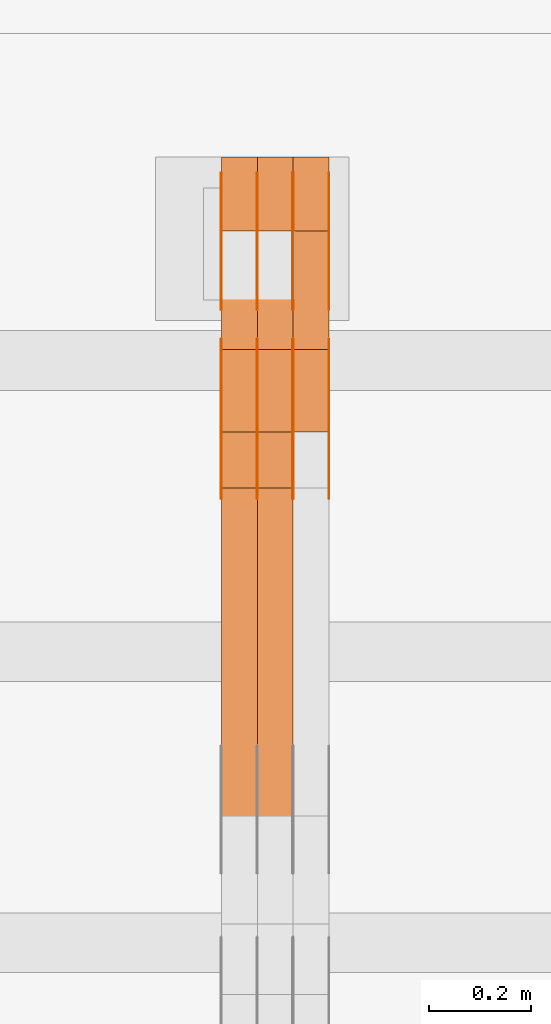
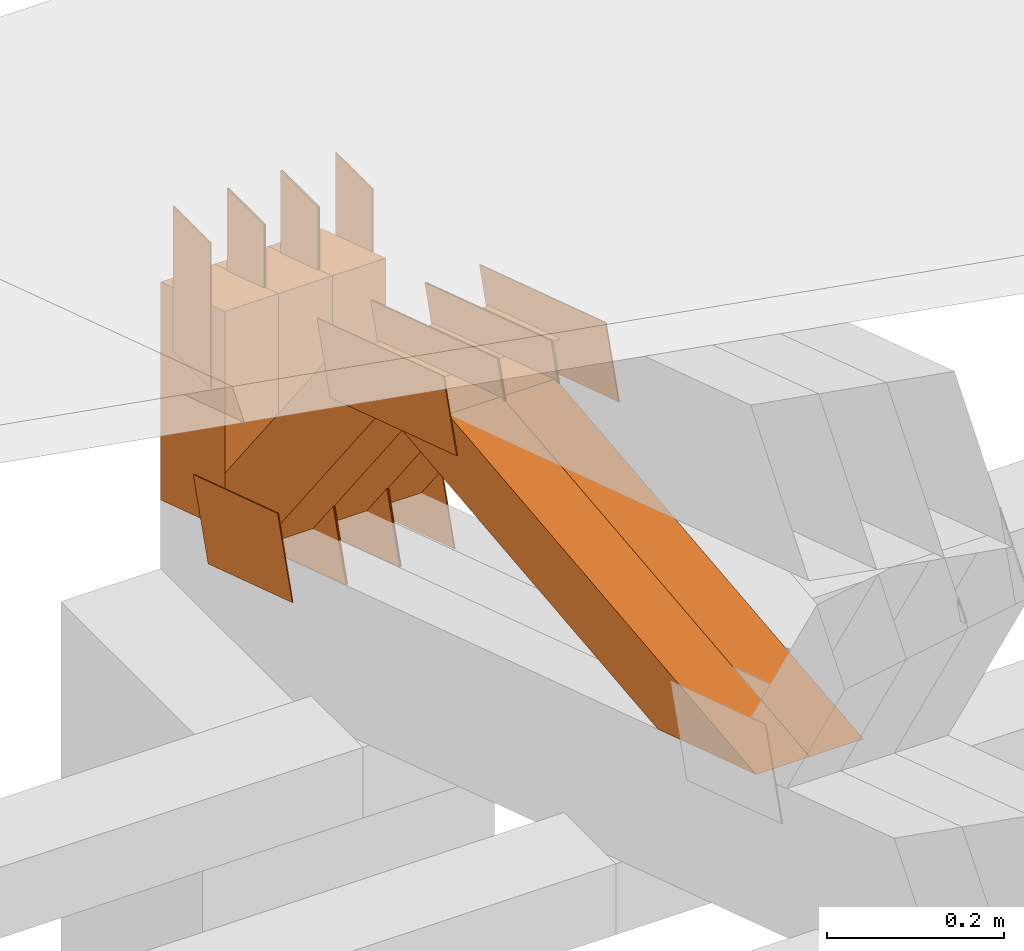
# One storey, part 242 of 385: 26 proxies.
"""IFC2X3 building model written with IfcOpenShell, lengths in millimetres."""

from ifc_helpers import new_model, entity, si_unit, converted_unit, derived_unit, direction, frame, frame_2d, origin, place, context, subcontext, project, spatial, polyline, rectangle, outline, extrude, source, transform, mapped, material, type_object, type_shapes, element, save


model = new_model("IFC2X3")

# Units and contexts
model_context = context("Model", 3, precision=0.01, world=origin(), true_north=direction((6.12303176911189e-17, 1.0)))
body_context = subcontext(model_context, "Body", "Model", "MODEL_VIEW")
ifc_project = project(units=[si_unit("LENGTHUNIT", "METRE", prefix="MILLI"), si_unit("AREAUNIT", "SQUARE_METRE"), si_unit("VOLUMEUNIT", "CUBIC_METRE"), converted_unit("PLANEANGLEUNIT", "DEGREE", entity("IfcRatioMeasure", 0.0174532925199433), si_unit("PLANEANGLEUNIT", "RADIAN"), dimensions=[0, 0, 0, 0, 0, 0, 0]), si_unit("MASSUNIT", "GRAM", prefix="KILO"), derived_unit("MASSDENSITYUNIT", [(si_unit("MASSUNIT", "GRAM", prefix="KILO"), 1), (si_unit("LENGTHUNIT", "METRE"), -3)]), si_unit("TIMEUNIT", "SECOND"), si_unit("FREQUENCYUNIT", "HERTZ"), si_unit("THERMODYNAMICTEMPERATUREUNIT", "DEGREE_CELSIUS"), derived_unit("THERMALTRANSMITTANCEUNIT", [(si_unit("MASSUNIT", "GRAM", prefix="KILO"), 1), (si_unit("THERMODYNAMICTEMPERATUREUNIT", "KELVIN"), -1), (si_unit("TIMEUNIT", "SECOND"), -3)]), derived_unit("VOLUMETRICFLOWRATEUNIT", [(si_unit("LENGTHUNIT", "METRE"), 3), (si_unit("TIMEUNIT", "SECOND"), -1)]), si_unit("ELECTRICCURRENTUNIT", "AMPERE"), si_unit("ELECTRICVOLTAGEUNIT", "VOLT"), si_unit("POWERUNIT", "WATT"), si_unit("FORCEUNIT", "NEWTON", prefix="KILO"), si_unit("ILLUMINANCEUNIT", "LUX"), si_unit("LUMINOUSFLUXUNIT", "LUMEN"), si_unit("LUMINOUSINTENSITYUNIT", "CANDELA"), derived_unit("USERDEFINED", [(si_unit("MASSUNIT", "GRAM", prefix="KILO"), -1), (si_unit("LENGTHUNIT", "METRE"), -2), (si_unit("TIMEUNIT", "SECOND"), 3), (si_unit("LUMINOUSFLUXUNIT", "LUMEN"), 1)]), derived_unit("LINEARVELOCITYUNIT", [(si_unit("LENGTHUNIT", "METRE"), 1), (si_unit("TIMEUNIT", "SECOND"), -1)]), si_unit("PRESSUREUNIT", "PASCAL"), derived_unit("USERDEFINED", [(si_unit("LENGTHUNIT", "METRE"), -2), (si_unit("MASSUNIT", "GRAM", prefix="KILO"), 1), (si_unit("TIMEUNIT", "SECOND"), -2)])], contexts=[model_context])

# Site, building, storey
site_placement = place(None, origin())
site = spatial("IfcSite", under=ifc_project, at=site_placement, CompositionType="ELEMENT")
building_placement = place(site_placement, origin())
building = spatial("IfcBuilding", under=site, at=building_placement, CompositionType="ELEMENT")
storey_placement = place(building_placement, origin())
storey = spatial("IfcBuildingStorey", under=building, at=storey_placement, Name="Default", CompositionType="ELEMENT", Elevation=0.0)

# Proxies
ifc_material_1 = material(Name="IfcSurfaceStyle #378222")
building_element_proxy_type_1 = type_object("IfcBuildingElementProxyType", PredefinedType="NOTDEFINED", material=ifc_material_1)
shared_shape_1 = source(origin(), body_context, "Body", "SweptSolid", [
    extrude(outline(polyline([(-100.000024997547, -54.0000105875654), (100.000088940899, -54.0000105875654), (99.9999100805868, 54.0000105875654), (-99.9999740239394, 54.0000105875654), (-100.000024997547, -54.0000105875654)])), frame((100.000088940899, 54.0000474633838, 0.0), z_axis=(0.0, 0.0, 1.0), x_axis=(-1.0, 0.0, 0.0)), (0.0, 0.0, 1.0), 1.3),
])
type_shapes(building_element_proxy_type_1, [shared_shape_1])
proxy_1_placement = place(building_placement, frame((30386.3, 26390.6212638563, 73.3227520411355), z_axis=(-1.0, 0.0, 0.0), x_axis=(0.0, -0.951056516295124, 0.309016994375039)))
element("IfcBuildingElementProxy", 1, at=proxy_1_placement, inside=storey, type_object=building_element_proxy_type_1, material=ifc_material_1, context=body_context, shape_type="MappedRepresentation", body=[
    mapped(shared_shape_1, transform((0.0, 0.0, 0.0), scale=1.0)),
])
ifc_material_2 = material(Name="IfcSurfaceStyle #378165")
building_element_proxy_type_2 = type_object("IfcBuildingElementProxyType", PredefinedType="NOTDEFINED", material=ifc_material_2)
shared_shape_2 = source(origin(), body_context, "Body", "SweptSolid", [
    extrude(outline(polyline([(-100.000024997547, -54.0000105875654), (100.000088940899, -54.0000105875654), (99.9999100805868, 54.0000105875654), (-99.9999740239394, 54.0000105875654), (-100.000024997547, -54.0000105875654)])), frame((100.000088940899, 54.0000474633838, 0.0), z_axis=(0.0, 0.0, 1.0), x_axis=(-1.0, 0.0, 0.0)), (0.0, 0.0, 1.0), 1.3),
])
type_shapes(building_element_proxy_type_2, [shared_shape_2])
proxy_2_placement = place(building_placement, frame((30315.0, 26390.6212638563, 73.3227520411355), z_axis=(-1.0, 0.0, 0.0), x_axis=(0.0, -0.951056516295124, 0.309016994375039)))
element("IfcBuildingElementProxy", 2, at=proxy_2_placement, inside=storey, type_object=building_element_proxy_type_2, material=ifc_material_2, context=body_context, shape_type="MappedRepresentation", body=[
    mapped(shared_shape_2, transform((0.0, 0.0, 0.0), scale=1.0)),
])
ifc_material_3 = material(Name="IfcSurfaceStyle #378108")
building_element_proxy_type_3 = type_object("IfcBuildingElementProxyType", PredefinedType="NOTDEFINED", material=ifc_material_3)
shared_shape_3 = source(origin(), body_context, "Body", "SweptSolid", [
    extrude(outline(polyline([(-100.000024997547, -54.0000105875654), (100.000088940899, -54.0000105875654), (99.9999100805868, 54.0000105875654), (-99.9999740239394, 54.0000105875654), (-100.000024997547, -54.0000105875654)])), frame((100.000088940899, 54.0000474633838, 0.0), z_axis=(0.0, 0.0, 1.0), x_axis=(-1.0, 0.0, 0.0)), (0.0, 0.0, 1.0), 1.3),
])
type_shapes(building_element_proxy_type_3, [shared_shape_3])
proxy_3_placement = place(building_placement, frame((30316.3, 26390.6212638563, 73.3227520411355), z_axis=(-1.0, 0.0, 0.0), x_axis=(0.0, -0.951056516295124, 0.309016994375039)))
element("IfcBuildingElementProxy", 3, at=proxy_3_placement, inside=storey, type_object=building_element_proxy_type_3, material=ifc_material_3, context=body_context, shape_type="MappedRepresentation", body=[
    mapped(shared_shape_3, transform((0.0, 0.0, 0.0), scale=1.0)),
])
ifc_material_4 = material(Name="IfcSurfaceStyle #378051")
building_element_proxy_type_4 = type_object("IfcBuildingElementProxyType", PredefinedType="NOTDEFINED", material=ifc_material_4)
shared_shape_4 = source(origin(), body_context, "Body", "SweptSolid", [
    extrude(outline(polyline([(-100.000024997547, -54.0000105875654), (100.000088940899, -54.0000105875654), (99.9999100805868, 54.0000105875654), (-99.9999740239394, 54.0000105875654), (-100.000024997547, -54.0000105875654)])), frame((100.000088940899, 54.0000474633838, 0.0), z_axis=(0.0, 0.0, 1.0), x_axis=(-1.0, 0.0, 0.0)), (0.0, 0.0, 1.0), 1.29999999999998),
])
type_shapes(building_element_proxy_type_4, [shared_shape_4])
proxy_4_placement = place(building_placement, frame((30245.0, 26390.6212638563, 73.3227520411355), z_axis=(-1.0, 0.0, 0.0), x_axis=(0.0, -0.951056516295124, 0.309016994375039)))
element("IfcBuildingElementProxy", 4, at=proxy_4_placement, inside=storey, type_object=building_element_proxy_type_4, material=ifc_material_4, context=body_context, shape_type="MappedRepresentation", body=[
    mapped(shared_shape_4, transform((0.0, 0.0, 0.0), scale=1.0)),
])
ifc_material_5 = material(Name="IfcSurfaceStyle #377994")
building_element_proxy_type_5 = type_object("IfcBuildingElementProxyType", PredefinedType="NOTDEFINED", material=ifc_material_5)
shared_shape_5 = source(origin(), body_context, "Body", "SweptSolid", [
    extrude(outline(polyline([(-100.000024997547, -54.0000105875654), (100.000088940899, -54.0000105875654), (99.9999100805868, 54.0000105875654), (-99.9999740239394, 54.0000105875654), (-100.000024997547, -54.0000105875654)])), frame((100.000088940899, 54.0000474633838, 0.0), z_axis=(0.0, 0.0, 1.0), x_axis=(-1.0, 0.0, 0.0)), (0.0, 0.0, 1.0), 1.29999999999998),
])
type_shapes(building_element_proxy_type_5, [shared_shape_5])
proxy_5_placement = place(building_placement, frame((30246.3, 26390.6212638563, 73.3227520411355), z_axis=(-1.0, 0.0, 0.0), x_axis=(0.0, -0.951056516295124, 0.309016994375039)))
element("IfcBuildingElementProxy", 5, at=proxy_5_placement, inside=storey, type_object=building_element_proxy_type_5, material=ifc_material_5, context=body_context, shape_type="MappedRepresentation", body=[
    mapped(shared_shape_5, transform((0.0, 0.0, 0.0), scale=1.0)),
])
ifc_material_6 = material(Name="IfcSurfaceStyle #377937")
building_element_proxy_type_6 = type_object("IfcBuildingElementProxyType", PredefinedType="NOTDEFINED", material=ifc_material_6)
shared_shape_6 = source(origin(), body_context, "Body", "SweptSolid", [
    extrude(outline(polyline([(-100.000024997547, -54.0000105875654), (100.000088940899, -54.0000105875654), (99.9999100805868, 54.0000105875654), (-99.9999740239394, 54.0000105875654), (-100.000024997547, -54.0000105875654)])), frame((100.000088940899, 54.0000474633838, 0.0), z_axis=(0.0, 0.0, 1.0), x_axis=(-1.0, 0.0, 0.0)), (0.0, 0.0, 1.0), 1.29999999999999),
])
type_shapes(building_element_proxy_type_6, [shared_shape_6])
proxy_6_placement = place(building_placement, frame((30175.0, 26390.6212638563, 73.3227520411355), z_axis=(-1.0, 0.0, 0.0), x_axis=(0.0, -0.951056516295124, 0.309016994375039)))
element("IfcBuildingElementProxy", 6, at=proxy_6_placement, inside=storey, type_object=building_element_proxy_type_6, material=ifc_material_6, context=body_context, shape_type="MappedRepresentation", body=[
    mapped(shared_shape_6, transform((0.0, 0.0, 0.0), scale=1.0)),
])
ifc_material_7 = material(Name="IfcSurfaceStyle #365568")
building_element_proxy_type_7 = type_object("IfcBuildingElementProxyType", PredefinedType="NOTDEFINED", material=ifc_material_7)
shared_shape_7 = source(origin(), body_context, "Body", "SweptSolid", [
    extrude(outline(polyline([(-149.999901061401, -48.0000057587028), (150.000035297123, -48.0000057587028), (149.999910491851, 48.0000057587028), (-150.000044727574, 48.0000057587028), (-149.999901061401, -48.0000057587028)])), frame((150.000035297123, 48.0000632585775, 0.0), z_axis=(0.0, 0.0, 1.0), x_axis=(-1.0, 0.0, 0.0)), (0.0, 0.0, 1.0), 1.29999999999999),
])
type_shapes(building_element_proxy_type_7, [shared_shape_7])
proxy_7_placement = place(building_placement, frame((30386.3, 26115.0176968219, 469.58296924555), z_axis=(-1.0, 0.0, 0.0), x_axis=(0.0, -0.951056516295154, 0.309016994374948)))
element("IfcBuildingElementProxy", 7, at=proxy_7_placement, inside=storey, type_object=building_element_proxy_type_7, material=ifc_material_7, context=body_context, shape_type="MappedRepresentation", body=[
    mapped(shared_shape_7, transform((0.0, 0.0, 0.0), scale=1.0)),
])
ifc_material_8 = material(Name="IfcSurfaceStyle #365511")
building_element_proxy_type_8 = type_object("IfcBuildingElementProxyType", PredefinedType="NOTDEFINED", material=ifc_material_8)
shared_shape_8 = source(origin(), body_context, "Body", "SweptSolid", [
    extrude(outline(polyline([(-149.999901061401, -48.0000057587028), (150.000035297123, -48.0000057587028), (149.999910491851, 48.0000057587028), (-150.000044727574, 48.0000057587028), (-149.999901061401, -48.0000057587028)])), frame((150.000035297123, 48.0000632585775, 0.0), z_axis=(0.0, 0.0, 1.0), x_axis=(-1.0, 0.0, 0.0)), (0.0, 0.0, 1.0), 1.29999999999999),
])
type_shapes(building_element_proxy_type_8, [shared_shape_8])
proxy_8_placement = place(building_placement, frame((30315.0, 26115.0176968219, 469.58296924555), z_axis=(-1.0, 0.0, 0.0), x_axis=(0.0, -0.951056516295154, 0.309016994374948)))
element("IfcBuildingElementProxy", 8, at=proxy_8_placement, inside=storey, type_object=building_element_proxy_type_8, material=ifc_material_8, context=body_context, shape_type="MappedRepresentation", body=[
    mapped(shared_shape_8, transform((0.0, 0.0, 0.0), scale=1.0)),
])
ifc_material_9 = material(Name="IfcSurfaceStyle #365454")
building_element_proxy_type_9 = type_object("IfcBuildingElementProxyType", PredefinedType="NOTDEFINED", material=ifc_material_9)
shared_shape_9 = source(origin(), body_context, "Body", "SweptSolid", [
    extrude(outline(polyline([(-149.999901061401, -48.0000057587028), (150.000035297123, -48.0000057587028), (149.999910491851, 48.0000057587028), (-150.000044727574, 48.0000057587028), (-149.999901061401, -48.0000057587028)])), frame((150.000035297123, 48.0000632585775, 0.0), z_axis=(0.0, 0.0, 1.0), x_axis=(-1.0, 0.0, 0.0)), (0.0, 0.0, 1.0), 1.29999999999999),
])
type_shapes(building_element_proxy_type_9, [shared_shape_9])
proxy_9_placement = place(building_placement, frame((30316.3, 26115.0176968219, 469.58296924555), z_axis=(-1.0, 0.0, 0.0), x_axis=(0.0, -0.951056516295154, 0.309016994374948)))
element("IfcBuildingElementProxy", 9, at=proxy_9_placement, inside=storey, type_object=building_element_proxy_type_9, material=ifc_material_9, context=body_context, shape_type="MappedRepresentation", body=[
    mapped(shared_shape_9, transform((0.0, 0.0, 0.0), scale=1.0)),
])
ifc_material_10 = material(Name="IfcSurfaceStyle #365397")
building_element_proxy_type_10 = type_object("IfcBuildingElementProxyType", PredefinedType="NOTDEFINED", material=ifc_material_10)
shared_shape_10 = source(origin(), body_context, "Body", "SweptSolid", [
    extrude(outline(polyline([(-149.999901061401, -48.0000057587028), (150.000035297123, -48.0000057587028), (149.999910491851, 48.0000057587028), (-150.000044727574, 48.0000057587028), (-149.999901061401, -48.0000057587028)])), frame((150.000035297123, 48.0000632585775, 0.0), z_axis=(0.0, 0.0, 1.0), x_axis=(-1.0, 0.0, 0.0)), (0.0, 0.0, 1.0), 1.29999999999998),
])
type_shapes(building_element_proxy_type_10, [shared_shape_10])
proxy_10_placement = place(building_placement, frame((30245.0, 26115.0176968219, 469.58296924555), z_axis=(-1.0, 0.0, 0.0), x_axis=(0.0, -0.951056516295154, 0.309016994374948)))
element("IfcBuildingElementProxy", 10, at=proxy_10_placement, inside=storey, type_object=building_element_proxy_type_10, material=ifc_material_10, context=body_context, shape_type="MappedRepresentation", body=[
    mapped(shared_shape_10, transform((0.0, 0.0, 0.0), scale=1.0)),
])
ifc_material_11 = material(Name="IfcSurfaceStyle #365340")
building_element_proxy_type_11 = type_object("IfcBuildingElementProxyType", PredefinedType="NOTDEFINED", material=ifc_material_11)
shared_shape_11 = source(origin(), body_context, "Body", "SweptSolid", [
    extrude(outline(polyline([(-149.999901061401, -48.0000057587028), (150.000035297123, -48.0000057587028), (149.999910491851, 48.0000057587028), (-150.000044727574, 48.0000057587028), (-149.999901061401, -48.0000057587028)])), frame((150.000035297123, 48.0000632585775, 0.0), z_axis=(0.0, 0.0, 1.0), x_axis=(-1.0, 0.0, 0.0)), (0.0, 0.0, 1.0), 1.29999999999998),
])
type_shapes(building_element_proxy_type_11, [shared_shape_11])
proxy_11_placement = place(building_placement, frame((30246.3, 26115.0176968219, 469.58296924555), z_axis=(-1.0, 0.0, 0.0), x_axis=(0.0, -0.951056516295154, 0.309016994374948)))
element("IfcBuildingElementProxy", 11, at=proxy_11_placement, inside=storey, type_object=building_element_proxy_type_11, material=ifc_material_11, context=body_context, shape_type="MappedRepresentation", body=[
    mapped(shared_shape_11, transform((0.0, 0.0, 0.0), scale=1.0)),
])
ifc_material_12 = material(Name="IfcSurfaceStyle #365283")
building_element_proxy_type_12 = type_object("IfcBuildingElementProxyType", PredefinedType="NOTDEFINED", material=ifc_material_12)
shared_shape_12 = source(origin(), body_context, "Body", "SweptSolid", [
    extrude(outline(polyline([(-149.999901061401, -48.0000057587028), (150.000035297123, -48.0000057587028), (149.999910491851, 48.0000057587028), (-150.000044727574, 48.0000057587028), (-149.999901061401, -48.0000057587028)])), frame((150.000035297123, 48.0000632585775, 0.0), z_axis=(0.0, 0.0, 1.0), x_axis=(-1.0, 0.0, 0.0)), (0.0, 0.0, 1.0), 1.29999999999998),
])
type_shapes(building_element_proxy_type_12, [shared_shape_12])
proxy_12_placement = place(building_placement, frame((30175.0, 26115.0176968219, 469.58296924555), z_axis=(-1.0, 0.0, 0.0), x_axis=(0.0, -0.951056516295154, 0.309016994374948)))
element("IfcBuildingElementProxy", 12, at=proxy_12_placement, inside=storey, type_object=building_element_proxy_type_12, material=ifc_material_12, context=body_context, shape_type="MappedRepresentation", body=[
    mapped(shared_shape_12, transform((0.0, 0.0, 0.0), scale=1.0)),
])
ifc_material_13 = material(Name="IfcSurfaceStyle #365226")
building_element_proxy_type_13 = type_object("IfcBuildingElementProxyType", PredefinedType="NOTDEFINED", material=ifc_material_13)
shared_shape_13 = source(origin(), body_context, "Body", "SweptSolid", [
    extrude(rectangle(XDim=200.0, YDim=84.0000000000005, at=frame_2d((-2.1316282072803e-14, 1.06581410364015e-14), x_axis=(1.0, 0.0))), frame((100.0, 42.0, 0.0), z_axis=(0.0, 0.0, 1.0), x_axis=(-1.0, 0.0, 0.0)), (0.0, 0.0, 1.0), 1.3),
])
type_shapes(building_element_proxy_type_13, [shared_shape_13])
proxy_13_placement = place(building_placement, frame((30386.3, 26469.5000000002, 518.521545410156), z_axis=(-1.0, 0.0, 0.0), x_axis=(0.0, 0.0, -1.0)))
element("IfcBuildingElementProxy", 13, at=proxy_13_placement, inside=storey, type_object=building_element_proxy_type_13, material=ifc_material_13, context=body_context, shape_type="MappedRepresentation", body=[
    mapped(shared_shape_13, transform((0.0, 0.0, 0.0), scale=1.0)),
])
ifc_material_14 = material(Name="IfcSurfaceStyle #365169")
building_element_proxy_type_14 = type_object("IfcBuildingElementProxyType", PredefinedType="NOTDEFINED", material=ifc_material_14)
shared_shape_14 = source(origin(), body_context, "Body", "SweptSolid", [
    extrude(rectangle(XDim=200.0, YDim=84.0000000000005, at=frame_2d((-2.1316282072803e-14, 1.06581410364015e-14), x_axis=(1.0, 0.0))), frame((100.0, 42.0, 0.0), z_axis=(0.0, 0.0, 1.0), x_axis=(-1.0, 0.0, 0.0)), (0.0, 0.0, 1.0), 1.3),
])
type_shapes(building_element_proxy_type_14, [shared_shape_14])
proxy_14_placement = place(building_placement, frame((30315.0, 26469.5000000002, 518.521545410156), z_axis=(-1.0, 0.0, 0.0), x_axis=(0.0, 0.0, -1.0)))
element("IfcBuildingElementProxy", 14, at=proxy_14_placement, inside=storey, type_object=building_element_proxy_type_14, material=ifc_material_14, context=body_context, shape_type="MappedRepresentation", body=[
    mapped(shared_shape_14, transform((0.0, 0.0, 0.0), scale=1.0)),
])
ifc_material_15 = material(Name="IfcSurfaceStyle #365112")
building_element_proxy_type_15 = type_object("IfcBuildingElementProxyType", PredefinedType="NOTDEFINED", material=ifc_material_15)
shared_shape_15 = source(origin(), body_context, "Body", "SweptSolid", [
    extrude(rectangle(XDim=200.0, YDim=84.0000000000005, at=frame_2d((-2.1316282072803e-14, 1.06581410364015e-14), x_axis=(1.0, 0.0))), frame((100.0, 42.0, 0.0), z_axis=(0.0, 0.0, 1.0), x_axis=(-1.0, 0.0, 0.0)), (0.0, 0.0, 1.0), 1.3),
])
type_shapes(building_element_proxy_type_15, [shared_shape_15])
proxy_15_placement = place(building_placement, frame((30316.3, 26469.5000000002, 518.521545410156), z_axis=(-1.0, 0.0, 0.0), x_axis=(0.0, 0.0, -1.0)))
element("IfcBuildingElementProxy", 15, at=proxy_15_placement, inside=storey, type_object=building_element_proxy_type_15, material=ifc_material_15, context=body_context, shape_type="MappedRepresentation", body=[
    mapped(shared_shape_15, transform((0.0, 0.0, 0.0), scale=1.0)),
])
ifc_material_16 = material(Name="IfcSurfaceStyle #365055")
building_element_proxy_type_16 = type_object("IfcBuildingElementProxyType", PredefinedType="NOTDEFINED", material=ifc_material_16)
shared_shape_16 = source(origin(), body_context, "Body", "SweptSolid", [
    extrude(rectangle(XDim=200.0, YDim=84.0000000000005, at=frame_2d((-2.1316282072803e-14, 1.06581410364015e-14), x_axis=(1.0, 0.0))), frame((100.0, 42.0, 0.0), z_axis=(0.0, 0.0, 1.0), x_axis=(-1.0, 0.0, 0.0)), (0.0, 0.0, 1.0), 1.29999999999998),
])
type_shapes(building_element_proxy_type_16, [shared_shape_16])
proxy_16_placement = place(building_placement, frame((30245.0, 26469.5000000002, 518.521545410156), z_axis=(-1.0, 0.0, 0.0), x_axis=(0.0, 0.0, -1.0)))
element("IfcBuildingElementProxy", 16, at=proxy_16_placement, inside=storey, type_object=building_element_proxy_type_16, material=ifc_material_16, context=body_context, shape_type="MappedRepresentation", body=[
    mapped(shared_shape_16, transform((0.0, 0.0, 0.0), scale=1.0)),
])
ifc_material_17 = material(Name="IfcSurfaceStyle #364998")
building_element_proxy_type_17 = type_object("IfcBuildingElementProxyType", PredefinedType="NOTDEFINED", material=ifc_material_17)
shared_shape_17 = source(origin(), body_context, "Body", "SweptSolid", [
    extrude(rectangle(XDim=200.0, YDim=84.0000000000005, at=frame_2d((-2.1316282072803e-14, 1.06581410364015e-14), x_axis=(1.0, 0.0))), frame((100.0, 42.0, 0.0), z_axis=(0.0, 0.0, 1.0), x_axis=(-1.0, 0.0, 0.0)), (0.0, 0.0, 1.0), 1.29999999999998),
])
type_shapes(building_element_proxy_type_17, [shared_shape_17])
proxy_17_placement = place(building_placement, frame((30246.3, 26469.5000000002, 518.521545410156), z_axis=(-1.0, 0.0, 0.0), x_axis=(0.0, 0.0, -1.0)))
element("IfcBuildingElementProxy", 17, at=proxy_17_placement, inside=storey, type_object=building_element_proxy_type_17, material=ifc_material_17, context=body_context, shape_type="MappedRepresentation", body=[
    mapped(shared_shape_17, transform((0.0, 0.0, 0.0), scale=1.0)),
])
ifc_material_18 = material(Name="IfcSurfaceStyle #364941")
building_element_proxy_type_18 = type_object("IfcBuildingElementProxyType", PredefinedType="NOTDEFINED", material=ifc_material_18)
shared_shape_18 = source(origin(), body_context, "Body", "SweptSolid", [
    extrude(rectangle(XDim=200.0, YDim=84.0000000000005, at=frame_2d((-2.1316282072803e-14, 1.06581410364015e-14), x_axis=(1.0, 0.0))), frame((100.0, 42.0, 0.0), z_axis=(0.0, 0.0, 1.0), x_axis=(-1.0, 0.0, 0.0)), (0.0, 0.0, 1.0), 1.29999999999999),
])
type_shapes(building_element_proxy_type_18, [shared_shape_18])
proxy_18_placement = place(building_placement, frame((30175.0, 26469.5000000002, 518.521545410156), z_axis=(-1.0, 0.0, 0.0), x_axis=(0.0, 0.0, -1.0)))
element("IfcBuildingElementProxy", 18, at=proxy_18_placement, inside=storey, type_object=building_element_proxy_type_18, material=ifc_material_18, context=body_context, shape_type="MappedRepresentation", body=[
    mapped(shared_shape_18, transform((0.0, 0.0, 0.0), scale=1.0)),
])
ifc_material_19 = material(Name="IfcSurfaceStyle #353748")
building_element_proxy_type_19 = type_object("IfcBuildingElementProxyType", Name="T1-W4 353746", PredefinedType="NOTDEFINED", material=ifc_material_19)
shared_shape_19 = source(origin(), body_context, "Body", "SweptSolid", [
    extrude(outline(polyline([(-510.077325435179, -47.4999981284922), (188.854793418912, -47.4999981284922), (294.906688207675, 1.67015383116809e-05), (324.289382923648, 47.499989777723), (-297.973539115057, 47.4999897777231), (-510.077325435179, -47.4999981284922)])), frame((324.289382923648, 47.5000278316275, 0.0), z_axis=(0.0, 0.0, 1.0), x_axis=(-1.0, 0.0, 0.0)), (0.0, 0.0, 1.0), 70.0),
])
type_shapes(building_element_proxy_type_19, [shared_shape_19])
proxy_19_placement = place(building_placement, frame((30315.0, 25996.2241251556, 525.69905884318), z_axis=(-1.0, 0.0, 0.0), x_axis=(0.0, -0.994287125203057, -0.106738524701444)))
element("IfcBuildingElementProxy", 19, at=proxy_19_placement, inside=storey, type_object=building_element_proxy_type_19, material=ifc_material_19, Name="T1-W4", context=body_context, shape_type="MappedRepresentation", body=[
    mapped(shared_shape_19, transform((0.0, 0.0, 0.0), scale=1.0)),
])
ifc_material_20 = material(Name="IfcSurfaceStyle #353682")
building_element_proxy_type_20 = type_object("IfcBuildingElementProxyType", Name="T1-W4 353680", PredefinedType="NOTDEFINED", material=ifc_material_20)
shared_shape_20 = source(origin(), body_context, "Body", "SweptSolid", [
    extrude(outline(polyline([(-510.077325435179, -47.4999981284922), (188.854793418912, -47.4999981284922), (294.906688207675, 1.67015383116809e-05), (324.289382923648, 47.499989777723), (-297.973539115057, 47.4999897777231), (-510.077325435179, -47.4999981284922)])), frame((324.289382923648, 47.5000278316275, 0.0), z_axis=(0.0, 0.0, 1.0), x_axis=(-1.0, 0.0, 0.0)), (0.0, 0.0, 1.0), 70.0),
])
type_shapes(building_element_proxy_type_20, [shared_shape_20])
proxy_20_placement = place(building_placement, frame((30245.0, 25996.2241251556, 525.69905884318), z_axis=(-1.0, 0.0, 0.0), x_axis=(0.0, -0.994287125203057, -0.106738524701444)))
element("IfcBuildingElementProxy", 20, at=proxy_20_placement, inside=storey, type_object=building_element_proxy_type_20, material=ifc_material_20, Name="T1-W4", context=body_context, shape_type="MappedRepresentation", body=[
    mapped(shared_shape_20, transform((0.0, 0.0, 0.0), scale=1.0)),
])
ifc_material_21 = material(Name="IfcSurfaceStyle #353418")
building_element_proxy_type_21 = type_object("IfcBuildingElementProxyType", Name="T1-W21 353416", PredefinedType="NOTDEFINED", material=ifc_material_21)
shared_shape_21 = source(origin(), body_context, "Body", "SweptSolid", [
    extrude(outline(polyline([(-209.199362597501, -47.5000308982766), (168.813164734153, -47.5000308982766), (229.900717355638, -2.18385470334148e-05), (159.828709317766, 47.5000418175501), (-349.343228810055, 47.5000418175502), (-209.199362597501, -47.5000308982766)])), frame((229.900720156071, 47.5000418175501, 0.0), z_axis=(0.0, 0.0, 1.0), x_axis=(-1.0, 0.0, 0.0)), (0.0, 0.0, 1.0), 70.0),
])
type_shapes(building_element_proxy_type_21, [shared_shape_21])
proxy_21_placement = place(building_placement, frame((30385.0, 26317.5019908272, 112.518372832984), z_axis=(-1.0, 0.0, 0.0), x_axis=(0.0, -0.613839629272042, 0.789430750310097)))
element("IfcBuildingElementProxy", 21, at=proxy_21_placement, inside=storey, type_object=building_element_proxy_type_21, material=ifc_material_21, Name="T1-W21", context=body_context, shape_type="MappedRepresentation", body=[
    mapped(shared_shape_21, transform((0.0, 0.0, 0.0), scale=1.0)),
])
ifc_material_22 = material(Name="IfcSurfaceStyle #353352")
building_element_proxy_type_22 = type_object("IfcBuildingElementProxyType", Name="T1-W21 353350", PredefinedType="NOTDEFINED", material=ifc_material_22)
shared_shape_22 = source(origin(), body_context, "Body", "SweptSolid", [
    extrude(outline(polyline([(-209.199362597501, -47.5000308982766), (168.813164734153, -47.5000308982766), (229.900717355638, -2.18385470334148e-05), (159.828709317766, 47.5000418175501), (-349.343228810055, 47.5000418175502), (-209.199362597501, -47.5000308982766)])), frame((229.900720156071, 47.5000418175501, 0.0), z_axis=(0.0, 0.0, 1.0), x_axis=(-1.0, 0.0, 0.0)), (0.0, 0.0, 1.0), 70.0),
])
type_shapes(building_element_proxy_type_22, [shared_shape_22])
proxy_22_placement = place(building_placement, frame((30315.0, 26317.5019908272, 112.518372832984), z_axis=(-1.0, 0.0, 0.0), x_axis=(0.0, -0.613839629272042, 0.789430750310097)))
element("IfcBuildingElementProxy", 22, at=proxy_22_placement, inside=storey, type_object=building_element_proxy_type_22, material=ifc_material_22, Name="T1-W21", context=body_context, shape_type="MappedRepresentation", body=[
    mapped(shared_shape_22, transform((0.0, 0.0, 0.0), scale=1.0)),
])
ifc_material_23 = material(Name="IfcSurfaceStyle #353286")
building_element_proxy_type_23 = type_object("IfcBuildingElementProxyType", Name="T1-W21 353284", PredefinedType="NOTDEFINED", material=ifc_material_23)
shared_shape_23 = source(origin(), body_context, "Body", "SweptSolid", [
    extrude(outline(polyline([(-209.199362597501, -47.5000308982766), (168.813164734153, -47.5000308982766), (229.900717355638, -2.18385470334148e-05), (159.828709317766, 47.5000418175501), (-349.343228810055, 47.5000418175502), (-209.199362597501, -47.5000308982766)])), frame((229.900720156071, 47.5000418175501, 0.0), z_axis=(0.0, 0.0, 1.0), x_axis=(-1.0, 0.0, 0.0)), (0.0, 0.0, 1.0), 70.0),
])
type_shapes(building_element_proxy_type_23, [shared_shape_23])
proxy_23_placement = place(building_placement, frame((30245.0, 26317.5019908272, 112.518372832984), z_axis=(-1.0, 0.0, 0.0), x_axis=(0.0, -0.613839629272042, 0.789430750310097)))
element("IfcBuildingElementProxy", 23, at=proxy_23_placement, inside=storey, type_object=building_element_proxy_type_23, material=ifc_material_23, Name="T1-W21", context=body_context, shape_type="MappedRepresentation", body=[
    mapped(shared_shape_23, transform((0.0, 0.0, 0.0), scale=1.0)),
])
ifc_material_24 = material(Name="IfcSurfaceStyle #352851")
building_element_proxy_type_24 = type_object("IfcBuildingElementProxyType", Name="T1-E2 352849", PredefinedType="NOTDEFINED", material=ifc_material_24)
shared_shape_24 = source(origin(), body_context, "Body", "SweptSolid", [
    extrude(outline(polyline([(-126.644535064697, -72.4999999999998), (173.757884979248, -72.4999999999998), (126.644542694092, 72.4999999999998), (-173.757892608642, 72.4999999999998), (-126.644535064697, -72.4999999999998)])), frame((173.757890653796, 72.5000000000002, 0.0), z_axis=(0.0, 0.0, 1.0), x_axis=(-1.0, 0.0, 0.0)), (0.0, 0.0, 1.0), 70.0),
])
type_shapes(building_element_proxy_type_24, [shared_shape_24])
proxy_24_placement = place(building_placement, frame((30385.0, 26500.0, 442.078222227283), z_axis=(-1.0, 0.0, 0.0), x_axis=(0.0, 0.0, -1.0)))
element("IfcBuildingElementProxy", 24, at=proxy_24_placement, inside=storey, type_object=building_element_proxy_type_24, material=ifc_material_24, Name="T1-E2", context=body_context, shape_type="MappedRepresentation", body=[
    mapped(shared_shape_24, transform((0.0, 0.0, 0.0), scale=1.0)),
])
ifc_material_25 = material(Name="IfcSurfaceStyle #352794")
building_element_proxy_type_25 = type_object("IfcBuildingElementProxyType", Name="T1-E2 352792", PredefinedType="NOTDEFINED", material=ifc_material_25)
shared_shape_25 = source(origin(), body_context, "Body", "SweptSolid", [
    extrude(outline(polyline([(-126.644535064697, -72.4999999999998), (173.757884979248, -72.4999999999998), (126.644542694092, 72.4999999999998), (-173.757892608642, 72.4999999999998), (-126.644535064697, -72.4999999999998)])), frame((173.757890653796, 72.5000000000002, 0.0), z_axis=(0.0, 0.0, 1.0), x_axis=(-1.0, 0.0, 0.0)), (0.0, 0.0, 1.0), 70.0),
])
type_shapes(building_element_proxy_type_25, [shared_shape_25])
proxy_25_placement = place(building_placement, frame((30315.0, 26500.0, 442.078222227283), z_axis=(-1.0, 0.0, 0.0), x_axis=(0.0, 0.0, -1.0)))
element("IfcBuildingElementProxy", 25, at=proxy_25_placement, inside=storey, type_object=building_element_proxy_type_25, material=ifc_material_25, Name="T1-E2", context=body_context, shape_type="MappedRepresentation", body=[
    mapped(shared_shape_25, transform((0.0, 0.0, 0.0), scale=1.0)),
])
ifc_material_26 = material(Name="IfcSurfaceStyle #352737")
building_element_proxy_type_26 = type_object("IfcBuildingElementProxyType", Name="T1-E2 352735", PredefinedType="NOTDEFINED", material=ifc_material_26)
shared_shape_26 = source(origin(), body_context, "Body", "SweptSolid", [
    extrude(outline(polyline([(-126.644535064697, -72.4999999999998), (173.757884979248, -72.4999999999998), (126.644542694092, 72.4999999999998), (-173.757892608642, 72.4999999999998), (-126.644535064697, -72.4999999999998)])), frame((173.757890653796, 72.5000000000002, 0.0), z_axis=(0.0, 0.0, 1.0), x_axis=(-1.0, 0.0, 0.0)), (0.0, 0.0, 1.0), 70.0),
])
type_shapes(building_element_proxy_type_26, [shared_shape_26])
proxy_26_placement = place(building_placement, frame((30245.0, 26500.0, 442.078222227283), z_axis=(-1.0, 0.0, 0.0), x_axis=(0.0, 0.0, -1.0)))
element("IfcBuildingElementProxy", 26, at=proxy_26_placement, inside=storey, type_object=building_element_proxy_type_26, material=ifc_material_26, Name="T1-E2", context=body_context, shape_type="MappedRepresentation", body=[
    mapped(shared_shape_26, transform((0.0, 0.0, 0.0), scale=1.0)),
])

save(model, "model.ifc")
